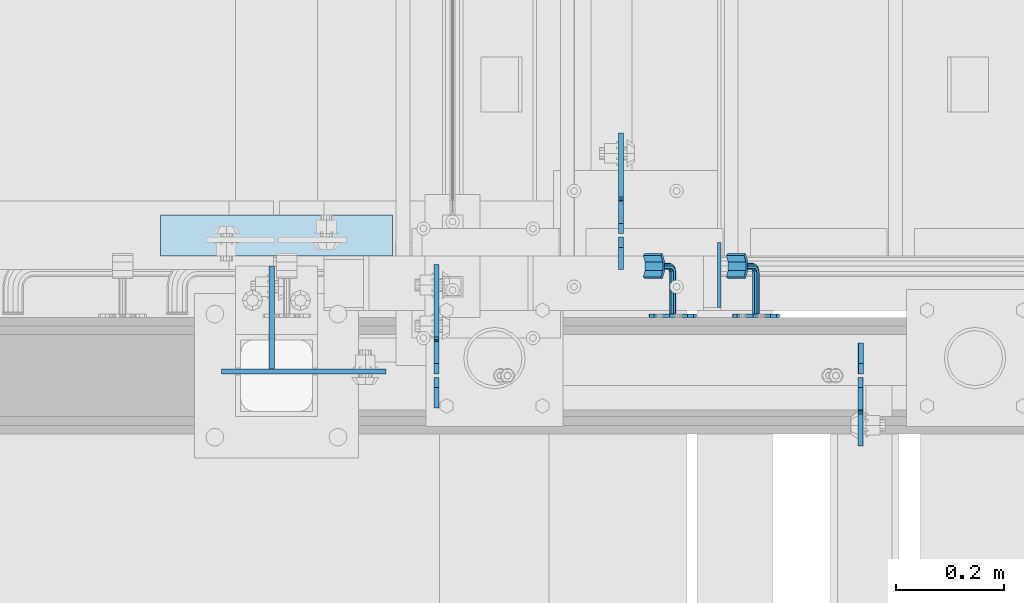
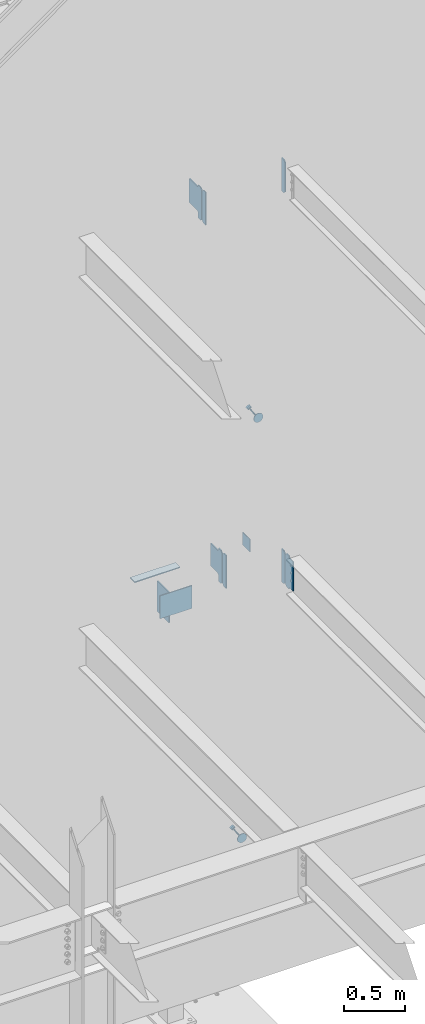
# One storey, part 1093 of 1179: 13 plates, 7 elements without a shape of their own.
"""IFC2X3 building model written with IfcOpenShell, lengths in millimetres."""

from ifc_helpers import new_model, si_unit, frame, origin_with_axes, place, context, subcontext, project, spatial, faceted_brep, material, type_object, element, aggregate, save


model = new_model("IFC2X3")

# Units and contexts
model_context = context("Model", 3, precision=1e-05, world=origin_with_axes())
body_context = subcontext(model_context, "Body", "Model", "MODEL_VIEW")
ifc_project = project(units=[si_unit("LENGTHUNIT", "METRE", prefix="MILLI"), si_unit("AREAUNIT", "SQUARE_METRE"), si_unit("VOLUMEUNIT", "CUBIC_METRE"), si_unit("MASSUNIT", "GRAM", prefix="KILO"), si_unit("TIMEUNIT", "SECOND"), si_unit("PLANEANGLEUNIT", "RADIAN"), si_unit("SOLIDANGLEUNIT", "STERADIAN"), si_unit("THERMODYNAMICTEMPERATUREUNIT", "DEGREE_CELSIUS"), si_unit("LUMINOUSINTENSITYUNIT", "LUMEN")], contexts=[model_context])

# Site, building, storey
site_placement = place(None, origin_with_axes())
site = spatial("IfcSite", under=ifc_project, at=site_placement, CompositionType="ELEMENT")
building_placement = place(site_placement, origin_with_axes())
building = spatial("IfcBuilding", under=site, at=building_placement, Name="Undefined", CompositionType="ELEMENT")
storey_placement = place(building_placement, origin_with_axes())
storey = spatial("IfcBuildingStorey", under=building, at=storey_placement, Name="Undefined", CompositionType="ELEMENT", Elevation=0.0)

# Assembly, plate
assembly_1_placement = place(storey_placement, origin_with_axes())
assembly_1 = element("IfcElementAssembly", 1, at=assembly_1_placement, inside=storey, Name="BEAM", AssemblyPlace="NOTDEFINED", PredefinedType="RIGID_FRAME")
ifc_material_1 = material(Name="STEEL/A36")
plate_type_1 = type_object("IfcPlateType", PredefinedType="NOTDEFINED")
plate_1_placement = place(assembly_1_placement, frame((20362.8620000839, 37982.525, 3762.375), z_axis=(0.0, 0.0, 1.0), x_axis=(0.0, -1.0, 0.0)))
plate_1 = element("IfcPlate", 2, at=plate_1_placement, type_object=plate_type_1, material=ifc_material_1, Name="PLATE", context=body_context, shape_type="Brep", body=[
    faceted_brep([(60.3249999999971, -4.76250000000073, 0.0), (60.3249999999971, 4.76250000000073, 0.0), (60.3250000523913, 4.76250000000073, 3.17500033034594), (60.3250000523913, -4.76250000000073, 3.17500033034594), (61.2917300150875, 4.76250000000073, 8.03507980551149), (61.2917300150875, -4.76250000000073, 8.03507980551149), (64.0447439248892, 4.76250000000073, 12.1552562262682), (64.0447439248892, -4.76250000000073, 12.1552562262682), (68.1649203759516, 4.76250000000073, 14.9082700907147), (68.1649203759516, -4.76250000000073, 14.9082700907147), (73.0249998617583, 4.76250000000073, 15.8749999999122), (73.0249998617583, -4.76250000000073, 15.8749999999122), (127.000004117435, -4.76250000000073, 15.8749999995416), (127.000004116067, 4.76250000000073, 15.8749999995416), (19.0499992370605, -4.76250000000073, 0.0), (0.0, -4.76250000000073, 19.0499992370605), (0.0, 4.76250000000073, 19.0499992370605), (19.0499992370605, 4.76250000000073, 0.0), (0.0, -4.76250000000073, 311.150012969971), (0.0, 4.76250000000073, 311.150012969971), (19.0499992370605, -4.76250000000073, 330.200012207031), (19.0499992370605, 4.76250000000073, 330.200012207031), (60.3250000095268, -4.76250000000073, 330.200000000001), (60.3250000095268, 4.76250000000073, 330.200000000001), (60.3250000714397, -4.76250000000073, 323.849999691947), (60.3250000714397, 4.76250000000073, 323.849999691947), (61.2917300265472, -4.76250000000073, 318.9899202097), (61.2917300265472, 4.76250000000073, 318.9899202097), (64.0447439338604, -4.76250000000073, 314.869743780706), (64.0447439338604, 4.76250000000073, 314.869743780706), (68.1649203869747, -4.76250000000073, 312.116729909506), (68.1649203869747, 4.76250000000073, 312.116729909506), (73.0249998776999, -4.76250000000073, 311.149999996991), (73.0249998776999, 4.76250000000073, 311.149999996991), (127.000004111091, -4.76250000000073, 311.149999984205), (127.000004116067, 4.76250000000073, 311.149999984205)], [[[0, 1, 2, 3]], [[3, 2, 4, 5]], [[5, 4, 6, 7]], [[7, 6, 8, 9]], [[9, 8, 10, 11]], [[12, 11, 10, 13]], [[14, 15, 16, 17]], [[15, 18, 19, 16]], [[18, 20, 21, 19]], [[21, 20, 22, 23]], [[22, 24, 25, 23]], [[26, 27, 25, 24]], [[28, 29, 27, 26]], [[30, 31, 29, 28]], [[32, 33, 31, 30]], [[34, 35, 33, 32]], [[35, 34, 12, 13]], [[8, 6, 4, 2, 1, 17, 16, 19, 21, 23, 25, 27, 29, 31, 33, 35, 13, 10]], [[0, 14, 17, 1]], [[34, 32, 30, 28, 26, 24, 22, 20, 18, 15, 14, 0, 3, 5, 7, 9, 11, 12]]]),
])

assembly_2_placement = place(storey_placement, origin_with_axes())
assembly_2 = element("IfcElementAssembly", 3, at=assembly_2_placement, inside=storey, Name="BEAM", AssemblyPlace="NOTDEFINED", PredefinedType="RIGID_FRAME")
plate_type_2 = type_object("IfcPlateType", PredefinedType="NOTDEFINED")
plate_2_placement = place(assembly_2_placement, frame((19575.4625, 37982.525, 7673.975), z_axis=(0.0, 0.0, 1.0), x_axis=(0.0, -1.0, 0.0)))
plate_2 = element("IfcPlate", 4, at=plate_2_placement, type_object=plate_type_2, material=ifc_material_1, Name="PLATE", context=body_context, shape_type="Brep", body=[
    faceted_brep([(0.0, -4.76250000000073, 19.0499992370605), (0.0, -4.76250000000073, 311.150012969971), (0.0, 4.76250000000073, 311.150012969971), (0.0, 4.76250000000073, 19.0499992370605), (19.0499992370605, -4.76250000000073, 330.200012207031), (19.0499992370605, 4.76250000000073, 330.200012207031), (57.1500015258789, -4.76250000000073, 330.200012207031), (57.1500015258789, 4.76250000000073, 330.200012207031), (57.1500015258789, -4.76250000000073, 0.0), (57.1500015258789, 4.76250000000073, 0.0), (19.0499992370605, -4.76250000000073, 0.0), (19.0499992370605, 4.76250000000073, 0.0)], [[[0, 1, 2, 3]], [[1, 4, 5, 2]], [[4, 6, 7, 5]], [[6, 8, 9, 7]], [[8, 10, 11, 9]], [[10, 0, 3, 11]], [[5, 7, 9, 11, 3, 2]], [[10, 8, 6, 4, 1, 0]]]),
])

# Plate
plate_3_placement = place(assembly_1_placement, frame((20362.8625, 37988.875, 3762.375), z_axis=(0.0, 0.0, 1.0), x_axis=(0.0, 1.0, 0.0)))
plate_3 = element("IfcPlate", 5, at=plate_3_placement, type_object=plate_type_2, material=ifc_material_1, Name="PLATE", context=body_context, shape_type="Brep", body=[
    faceted_brep([(0.0, -4.76250000000073, 19.0499992370605), (0.0, -4.76250000000073, 311.150012969971), (0.0, 4.76250000000073, 311.150012969971), (0.0, 4.76250000000073, 19.0499992370605), (19.0499992370605, -4.76250000000073, 330.200012207031), (19.0499992370605, 4.76250000000073, 330.200012207031), (57.1500015258789, -4.76250000000073, 330.200012207031), (57.1500015258789, 4.76250000000073, 330.200012207031), (57.1500015258789, -4.76250000000073, 0.0), (57.1500015258789, 4.76250000000073, 0.0), (19.0499992370605, -4.76250000000073, 0.0), (19.0499992370605, 4.76250000000073, 0.0)], [[[0, 1, 2, 3]], [[1, 4, 5, 2]], [[4, 6, 7, 5]], [[6, 8, 9, 7]], [[8, 10, 11, 9]], [[10, 0, 3, 11]], [[5, 7, 9, 11, 3, 2]], [[10, 8, 6, 4, 1, 0]]]),
])

aggregate(assembly_1, [plate_3, plate_1])

plate_4_placement = place(assembly_2_placement, frame((20363.6556310585, 37988.875, 7673.975), z_axis=(0.0, 0.0, 1.0), x_axis=(0.0, 1.0, 0.0)))
plate_4 = element("IfcPlate", 6, at=plate_4_placement, type_object=plate_type_2, material=ifc_material_1, Name="PLATE", context=body_context, shape_type="Brep", body=[
    faceted_brep([(0.0, -4.76250000000073, 19.0499992370605), (0.0, -4.76250000000073, 311.150012969971), (0.0, 4.76250000000073, 311.150012969971), (0.0, 4.76250000000073, 19.0499992370605), (19.0499992370605, -4.76250000000073, 330.200012207031), (19.0499992370605, 4.76250000000073, 330.200012207031), (57.1500015258789, -4.76250000000073, 330.200012207031), (57.1500015258789, 4.76250000000073, 330.200012207031), (57.1500015258789, -4.76250000000073, 0.0), (57.1500015258789, 4.76250000000073, 0.0), (19.0499992370605, -4.76250000000073, 0.0), (19.0499992370605, 4.76250000000073, 0.0)], [[[0, 1, 2, 3]], [[1, 4, 5, 2]], [[4, 6, 7, 5]], [[6, 8, 9, 7]], [[8, 10, 11, 9]], [[10, 0, 3, 11]], [[5, 7, 9, 11, 3, 2]], [[10, 8, 6, 4, 1, 0]]]),
])

# Assembly, plate
assembly_3_placement = place(storey_placement, origin_with_axes())
assembly_3 = element("IfcElementAssembly", 7, at=assembly_3_placement, inside=storey, Name="HANDRAIL", AssemblyPlace="NOTDEFINED", PredefinedType="RIGID_FRAME")
ifc_material_2 = material(Name="STEEL/BUY-OUT")
plate_type_3 = type_object("IfcPlateType", PredefinedType="NOTDEFINED")
plate_5_placement = place(assembly_3_placement, frame((20229.7217042504, 38096.8249999748, 5420.57110500949), z_axis=(-0.503209296841367, 0.0, 0.864164569727559), x_axis=(-0.864164569727559, 0.0, -0.503209296841368)))
plate_5 = element("IfcPlate", 8, at=plate_5_placement, type_object=plate_type_3, material=ifc_material_2, Name="BRACKET", context=body_context, shape_type="Brep", body=[
    faceted_brep([(3.38355483805572, -3.17500000000291, 61.4602780976829), (13.0191037998557, -3.17500000000291, 75.8808962003231), (13.0191037998557, 3.17500000000291, 75.8808962003231), (3.38355483805572, 3.17500000000291, 61.4602780976829), (27.439721902505, -3.17500000000291, 85.5164451621013), (27.439721902505, 3.17500000000291, 85.5164451621013), (44.449999237233, -3.17500000000291, 88.900000000056), (44.449999237233, 3.17500000000291, 88.900000000056), (61.4602780978275, -3.17500000000291, 85.5164451621104), (61.4602780978275, 3.17500000000291, 85.5164451621104), (75.8808962004478, -3.17500000000291, 75.8808962003413), (75.8808962004478, 3.17500000000291, 75.8808962003413), (85.5164451621931, -3.17500000000291, 61.4602780977075), (85.5164451621931, 3.17500000000291, 61.4602780977075), (88.9000000001142, -3.17500000000291, 44.4500007629867), (88.9000000001142, 3.17500000000291, 44.4500007629867), (85.5164451621349, -3.17500000000291, 27.4397219023849), (85.5164451621349, 3.17500000000291, 27.4397219023849), (75.880896200335, -3.17500000000291, 13.0191037997447), (75.880896200335, 3.17500000000291, 13.0191037997447), (61.460278097682, -3.17500000000291, 3.38355483796659), (61.460278097682, 3.17500000000291, 3.38355483796659), (44.450000762954, -3.17500000000291, 1.18234311230481e-11), (44.450000762954, 3.17500000000291, 1.18234311230481e-11), (27.4397219023631, -3.17500000000291, 3.38355483795749), (27.4397219023631, 3.17500000000291, 3.38355483795749), (13.0191037997429, -3.17500000000291, 13.0191037997274), (13.0191037997429, 3.17500000000291, 13.0191037997274), (3.38355483799751, -3.17500000000291, 27.4397219023613), (3.38355483799751, 3.17500000000291, 27.4397219023613), (7.6397554948926e-11, -3.17500000000291, 44.4500007629631), (7.6397554948926e-11, 3.17500000000291, 44.4500007629631), (50.7999999913809, -79.375000189706, 44.450000918423), (48.9401280518978, -79.375000189706, 39.9598728578721), (48.9401280518978, -3.17500000000291, 39.9598728578721), (50.7999999913809, -3.17500000000291, 44.450000918423), (44.4499999913533, -79.375000189706, 38.1000009183936), (44.4499999913533, -3.17500000000291, 38.1000009183936), (39.9598719308196, -79.375000189706, 39.9598728578549), (39.9598719308196, -3.17500000000291, 39.9598728578549), (38.0999999913656, -79.375000189706, 44.4500009184003), (38.0999999913656, -3.17500000000291, 44.4500009184003), (39.9598719308487, -79.375000189706, 48.940128978953), (39.9598719308487, -3.17500000000291, 48.940128978953), (44.4499999903783, -79.375000189706, 50.8000009184298), (48.9401280519305, -79.375000189706, 48.9401289789685), (48.9401280519305, -3.17500000000291, 48.9401289789685), (44.4499999913933, -3.17500000000291, 50.8000009184325), (48.940128050941, -83.4799360644611, 50.0400432323731), (50.7999999909662, -85.7250000949134, 46.1514782660752), (48.9401280520542, -87.9700641252057, 42.2629132991351), (44.4499999917462, -88.9000000947854, 40.6522169510108), (39.9598719309761, -87.9700641248055, 42.2629132975717), (38.0999999909509, -85.7250000943604, 46.1514782638696), (39.9598719298592, -83.4799360640682, 50.0400432308115), (44.4499999901709, -82.5500000944885, 51.6507395789349), (44.4499999895997, -84.8742613387294, 53.9750008233668), (48.9401280502061, -86.4849576864799, 53.0450648546439), (39.9598719291243, -86.4849576858032, 53.0450648527949), (38.0999999898122, -90.3735226524441, 50.8000008223462), (39.9598719294336, -94.262087619376, 48.554936792666), (44.4499999900399, -95.8727839671337, 47.6250008239376), (48.9401280505153, -94.2620876200599, 48.5549367945105), (50.7999999898311, -90.3735226534118, 50.8000008249601), (48.940128049202, -87.5848719388305, 57.150000729499), (50.7999999882741, -92.0749999995314, 57.1500007303257), (44.4499999882682, -85.7249999989726, 57.1500007282275), (39.9598719281203, -87.5848719380447, 57.1500007272562), (38.0999999882624, -92.0749999984182, 57.1500007271543), (39.9598719273345, -96.5651280591119, 57.150000727981), (44.4499999877116, -98.4249999989697, 57.1500007292507), (48.9401280484162, -96.5651280598977, 57.150000730222), (48.94012803636, -96.5651280554303, 107.980205186974), (50.7999999758504, -92.0749999949039, 107.980205187367), (44.4499999758082, -98.4249999948734, 107.980205185997), (39.9598719152818, -96.5651280553866, 107.980205185009), (38.0999999758387, -92.0749999948384, 107.980205184591), (39.9598719153255, -87.5848719343194, 107.980205184981), (44.4499999758445, -85.7249999948763, 107.980205185959), (48.9401280364073, -87.584871934363, 107.980205186946), (63.4999999710089, -112.173153287971, 121.386761918008), (25.3999999709486, -112.173153273812, 121.386761909694), (25.3999999709413, -115.348153273233, 115.887500595331), (63.499999970998, -115.348153287392, 115.887500603646), (63.4999999770953, -99.950838506069, 114.330205190187), (25.3999999770385, -99.9508384918445, 114.330205181834), (63.4999999830179, -84.3037932516017, 114.330205190117), (25.3999999829539, -84.3037932373336, 114.330205181805), (63.4999999860993, -72.081478471373, 121.386761924126), (25.3999999860353, -72.0814784571267, 121.386761915784), (25.3999999849657, -82.6023158642492, 107.980205181794), (25.3999999777625, -101.652315863423, 107.98020518183), (25.3999999884181, -68.9064784552756, 115.887500602809), (63.4999999778265, -101.652315877654, 107.980205190185), (63.4999999850261, -82.6023158785247, 107.980205190103), (63.4999999884785, -68.906478469522, 115.887500611152)], [[[0, 1, 2, 3]], [[1, 4, 5, 2]], [[4, 6, 7, 5]], [[6, 8, 9, 7]], [[8, 10, 11, 9]], [[10, 12, 13, 11]], [[12, 14, 15, 13]], [[14, 16, 17, 15]], [[16, 18, 19, 17]], [[18, 20, 21, 19]], [[20, 22, 23, 21]], [[22, 24, 25, 23]], [[24, 26, 27, 25]], [[26, 28, 29, 27]], [[28, 30, 31, 29]], [[2, 5, 7, 9, 11, 13, 15, 17, 19, 21, 23, 25, 27, 29, 31, 3]], [[30, 0, 3, 31]], [[32, 33, 34, 35]], [[33, 36, 37, 34]], [[36, 38, 39, 37]], [[38, 40, 41, 39]], [[40, 42, 43, 41]], [[44, 45, 46, 47]], [[42, 44, 47, 43]], [[28, 26, 24, 22, 20, 18, 16, 14, 12, 10, 8, 6, 4, 1, 0, 30], [46, 35, 34, 37, 39, 41, 43, 47]], [[45, 32, 35, 46]], [[32, 45, 48, 49]], [[33, 32, 49, 50]], [[36, 33, 50, 51]], [[38, 36, 51, 52]], [[40, 38, 52, 53]], [[42, 40, 53, 54]], [[44, 42, 54, 55]], [[45, 44, 55, 48]], [[55, 56, 57, 48]], [[54, 58, 56, 55]], [[53, 59, 58, 54]], [[52, 60, 59, 53]], [[51, 61, 60, 52]], [[50, 62, 61, 51]], [[49, 63, 62, 50]], [[48, 57, 63, 49]], [[57, 64, 65, 63]], [[56, 66, 64, 57]], [[58, 67, 66, 56]], [[59, 68, 67, 58]], [[60, 69, 68, 59]], [[61, 70, 69, 60]], [[62, 71, 70, 61]], [[63, 65, 71, 62]], [[72, 71, 65, 73]], [[74, 70, 71, 72]], [[75, 69, 70, 74]], [[76, 68, 69, 75]], [[77, 67, 68, 76]], [[78, 66, 67, 77]], [[79, 64, 66, 78]], [[73, 65, 64, 79]], [[80, 81, 82, 83]], [[81, 80, 84, 85]], [[85, 84, 86, 87]], [[87, 86, 88, 89]], [[90, 91, 82, 81, 85, 87, 89, 92]], [[83, 82, 91, 93]], [[86, 84, 80, 83, 93, 94, 95, 88]], [[89, 88, 95, 92]], [[94, 90, 92, 95]], [[93, 91, 90, 94], [78, 77, 76, 75, 74, 72, 73, 79]]]),
])
aggregate(assembly_3, [plate_5])

assembly_4_placement = place(storey_placement, origin_with_axes())
assembly_4 = element("IfcElementAssembly", 9, at=assembly_4_placement, inside=storey, Name="HANDRAIL", AssemblyPlace="NOTDEFINED", PredefinedType="RIGID_FRAME")
plate_6_placement = place(assembly_4_placement, frame((20075.1918322975, 38096.8249999748, 1269.24367168925), z_axis=(-0.500231016985973, 0.0, 0.865891984975712), x_axis=(-0.865891984975713, 0.0, -0.500231016985972)))
plate_6 = element("IfcPlate", 10, at=plate_6_placement, type_object=plate_type_3, material=ifc_material_2, Name="BRACKET", context=body_context, shape_type="Brep", body=[
    faceted_brep([(3.38355483805572, -3.17500000000291, 61.4602780976829), (13.0191037998557, -3.17500000000291, 75.8808962003231), (13.0191037998557, 3.17500000000291, 75.8808962003231), (3.38355483805572, 3.17500000000291, 61.4602780976829), (27.439721902505, -3.17500000000291, 85.5164451621013), (27.439721902505, 3.17500000000291, 85.5164451621013), (44.449999237233, -3.17500000000291, 88.900000000056), (44.449999237233, 3.17500000000291, 88.900000000056), (61.4602780978275, -3.17500000000291, 85.5164451621104), (61.4602780978275, 3.17500000000291, 85.5164451621104), (75.8808962004478, -3.17500000000291, 75.8808962003413), (75.8808962004478, 3.17500000000291, 75.8808962003413), (85.5164451621931, -3.17500000000291, 61.4602780977075), (85.5164451621931, 3.17500000000291, 61.4602780977075), (88.9000000001142, -3.17500000000291, 44.4500007629867), (88.9000000001142, 3.17500000000291, 44.4500007629867), (85.5164451621349, -3.17500000000291, 27.4397219023849), (85.5164451621349, 3.17500000000291, 27.4397219023849), (75.880896200335, -3.17500000000291, 13.0191037997447), (75.880896200335, 3.17500000000291, 13.0191037997447), (61.460278097682, -3.17500000000291, 3.38355483796659), (61.460278097682, 3.17500000000291, 3.38355483796659), (44.450000762954, -3.17500000000291, 1.18234311230481e-11), (44.450000762954, 3.17500000000291, 1.18234311230481e-11), (27.4397219023631, -3.17500000000291, 3.38355483795749), (27.4397219023631, 3.17500000000291, 3.38355483795749), (13.0191037997429, -3.17500000000291, 13.0191037997274), (13.0191037997429, 3.17500000000291, 13.0191037997274), (3.38355483799751, -3.17500000000291, 27.4397219023613), (3.38355483799751, 3.17500000000291, 27.4397219023613), (7.6397554948926e-11, -3.17500000000291, 44.4500007629631), (7.6397554948926e-11, 3.17500000000291, 44.4500007629631), (50.7999999913809, -79.375000189706, 44.450000918423), (48.9401280518978, -79.375000189706, 39.9598728578721), (48.9401280518978, -3.17500000000291, 39.9598728578721), (50.7999999913809, -3.17500000000291, 44.450000918423), (44.4499999913533, -79.375000189706, 38.1000009183936), (44.4499999913533, -3.17500000000291, 38.1000009183936), (39.9598719308196, -79.375000189706, 39.9598728578549), (39.9598719308196, -3.17500000000291, 39.9598728578549), (38.0999999913656, -79.375000189706, 44.4500009184003), (38.0999999913656, -3.17500000000291, 44.4500009184003), (39.9598719308487, -79.375000189706, 48.940128978953), (39.9598719308487, -3.17500000000291, 48.940128978953), (44.4499999903783, -79.375000189706, 50.8000009184298), (48.9401280519305, -79.375000189706, 48.9401289789685), (48.9401280519305, -3.17500000000291, 48.9401289789685), (44.4499999913933, -3.17500000000291, 50.8000009184325), (48.940128050941, -83.4799360644611, 50.0400432323731), (50.7999999909662, -85.7250000949134, 46.1514782660752), (48.9401280520542, -87.9700641252057, 42.2629132991351), (44.4499999917462, -88.9000000947854, 40.6522169510108), (39.9598719309761, -87.9700641248055, 42.2629132975717), (38.0999999909509, -85.7250000943604, 46.1514782638696), (39.9598719298592, -83.4799360640682, 50.0400432308115), (44.4499999901709, -82.5500000944885, 51.6507395789349), (44.4499999895997, -84.8742613387294, 53.9750008233668), (48.9401280502061, -86.4849576864799, 53.0450648546439), (39.9598719291243, -86.4849576858032, 53.0450648527949), (38.0999999898122, -90.3735226524441, 50.8000008223462), (39.9598719294336, -94.262087619376, 48.554936792666), (44.4499999900399, -95.8727839671337, 47.6250008239376), (48.9401280505153, -94.2620876200599, 48.5549367945105), (50.7999999898311, -90.3735226534118, 50.8000008249601), (48.940128049202, -87.5848719388305, 57.150000729499), (50.7999999882741, -92.0749999995314, 57.1500007303257), (44.4499999882682, -85.7249999989726, 57.1500007282275), (39.9598719281203, -87.5848719380447, 57.1500007272562), (38.0999999882624, -92.0749999984182, 57.1500007271543), (39.9598719273345, -96.5651280591119, 57.150000727981), (44.4499999877116, -98.4249999989697, 57.1500007292507), (48.9401280484162, -96.5651280598977, 57.150000730222), (48.94012803636, -96.5651280554303, 107.980205186974), (50.7999999758504, -92.0749999949039, 107.980205187367), (44.4499999758082, -98.4249999948734, 107.980205185997), (39.9598719152818, -96.5651280553866, 107.980205185009), (38.0999999758387, -92.0749999948384, 107.980205184591), (39.9598719153255, -87.5848719343194, 107.980205184981), (44.4499999758445, -85.7249999948763, 107.980205185959), (48.9401280364073, -87.584871934363, 107.980205186946), (63.4999999710089, -112.173153287971, 121.386761918008), (25.3999999709486, -112.173153273812, 121.386761909694), (25.3999999709413, -115.348153273233, 115.887500595331), (63.499999970998, -115.348153287392, 115.887500603646), (63.4999999770953, -99.950838506069, 114.330205190187), (25.3999999770385, -99.9508384918445, 114.330205181834), (63.4999999830179, -84.3037932516017, 114.330205190117), (25.3999999829539, -84.3037932373336, 114.330205181805), (63.4999999860993, -72.081478471373, 121.386761924126), (25.3999999860353, -72.0814784571267, 121.386761915784), (25.3999999849657, -82.6023158642492, 107.980205181794), (25.3999999777625, -101.652315863423, 107.98020518183), (25.3999999884181, -68.9064784552756, 115.887500602809), (63.4999999778265, -101.652315877654, 107.980205190185), (63.4999999850261, -82.6023158785247, 107.980205190103), (63.4999999884785, -68.906478469522, 115.887500611152)], [[[0, 1, 2, 3]], [[1, 4, 5, 2]], [[4, 6, 7, 5]], [[6, 8, 9, 7]], [[8, 10, 11, 9]], [[10, 12, 13, 11]], [[12, 14, 15, 13]], [[14, 16, 17, 15]], [[16, 18, 19, 17]], [[18, 20, 21, 19]], [[20, 22, 23, 21]], [[22, 24, 25, 23]], [[24, 26, 27, 25]], [[26, 28, 29, 27]], [[28, 30, 31, 29]], [[2, 5, 7, 9, 11, 13, 15, 17, 19, 21, 23, 25, 27, 29, 31, 3]], [[30, 0, 3, 31]], [[32, 33, 34, 35]], [[33, 36, 37, 34]], [[36, 38, 39, 37]], [[38, 40, 41, 39]], [[40, 42, 43, 41]], [[44, 45, 46, 47]], [[42, 44, 47, 43]], [[28, 26, 24, 22, 20, 18, 16, 14, 12, 10, 8, 6, 4, 1, 0, 30], [46, 35, 34, 37, 39, 41, 43, 47]], [[45, 32, 35, 46]], [[32, 45, 48, 49]], [[33, 32, 49, 50]], [[36, 33, 50, 51]], [[38, 36, 51, 52]], [[40, 38, 52, 53]], [[42, 40, 53, 54]], [[44, 42, 54, 55]], [[45, 44, 55, 48]], [[55, 56, 57, 48]], [[54, 58, 56, 55]], [[53, 59, 58, 54]], [[52, 60, 59, 53]], [[51, 61, 60, 52]], [[50, 62, 61, 51]], [[49, 63, 62, 50]], [[48, 57, 63, 49]], [[57, 64, 65, 63]], [[56, 66, 64, 57]], [[58, 67, 66, 56]], [[59, 68, 67, 58]], [[60, 69, 68, 59]], [[61, 70, 69, 60]], [[62, 71, 70, 61]], [[63, 65, 71, 62]], [[72, 71, 65, 73]], [[74, 70, 71, 72]], [[75, 69, 70, 74]], [[76, 68, 69, 75]], [[77, 67, 68, 76]], [[78, 66, 67, 77]], [[79, 64, 66, 78]], [[73, 65, 64, 79]], [[80, 81, 82, 83]], [[81, 80, 84, 85]], [[85, 84, 86, 87]], [[87, 86, 88, 89]], [[90, 91, 82, 81, 85, 87, 89, 92]], [[83, 82, 91, 93]], [[86, 84, 80, 83, 93, 94, 95, 88]], [[89, 88, 95, 92]], [[94, 90, 92, 95]], [[93, 91, 90, 94], [78, 77, 76, 75, 74, 72, 73, 79]]]),
])
aggregate(assembly_4, [plate_6])

assembly_5_placement = place(storey_placement, origin_with_axes())
assembly_5 = element("IfcElementAssembly", 11, at=assembly_5_placement, inside=storey, Name="COLUMN", AssemblyPlace="NOTDEFINED", PredefinedType="RIGID_FRAME")
plate_type_4 = type_object("IfcPlateType", PredefinedType="NOTDEFINED")
plate_7_placement = place(assembly_5_placement, frame((19367.5, 37993.6375, 4064.0), z_axis=(0.0, 0.0, -1.0), x_axis=(-1.0, 0.0, 0.0)))
plate_7 = element("IfcPlate", 12, at=plate_7_placement, type_object=plate_type_4, material=ifc_material_1, Name="PLATE", context=body_context, shape_type="Brep", body=[
    faceted_brep([(0.0, -4.76249999999709, 0.0), (-114.300000000003, -4.76250000000073, 0.0), (-114.300000000003, 4.76250000000073, 0.0), (0.0, 4.76249999999709, 0.0), (-114.299999999999, -4.76249999999709, 228.599999999999), (-114.299999999999, 4.76249999999709, 228.599999999999), (190.5, -4.76249999999709, 228.599999999999), (190.5, 4.76249999999709, 228.599999999999), (190.5, -4.76249999999709, 0.0), (190.5, 4.76249999999709, 0.0)], [[[0, 1, 2, 3]], [[1, 4, 5, 2]], [[4, 6, 7, 5]], [[6, 8, 9, 7]], [[8, 0, 3, 9]], [[5, 7, 9, 3, 2]], [[8, 6, 4, 1, 0]]]),
])

assembly_6_placement = place(storey_placement, origin_with_axes())
assembly_6 = element("IfcElementAssembly", 13, at=assembly_6_placement, inside=storey, Name="PLATE", AssemblyPlace="NOTDEFINED", PredefinedType="RIGID_FRAME")
plate_type_5 = type_object("IfcPlateType", PredefinedType="NOTDEFINED")
plate_8_placement = place(assembly_6_placement, frame((19493.70625, 38284.1500000005, 4106.8625), z_axis=(0.0, -1.0, 0.0), x_axis=(-1.0, 0.0, 0.0)))
plate_8 = element("IfcPlate", 14, at=plate_8_placement, type_object=plate_type_5, material=ifc_material_1, Name="PLATE", context=body_context, shape_type="Brep", body=[
    faceted_brep([(0.0, -4.76249999999709, 0.0), (0.0, -4.76249999999982, 76.1999999999971), (0.0, 4.76249999999982, 76.1999999999971), (0.0, 4.76249999999709, 0.0), (430.212500000001, -4.76249999999982, 76.1999999999971), (430.212500000001, 4.76249999999982, 76.1999999999971), (430.212500000001, -4.76249999999982, 0.0), (430.212500000001, 4.76249999999982, 0.0)], [[[0, 1, 2, 3]], [[1, 4, 5, 2]], [[4, 6, 7, 5]], [[6, 0, 3, 7]], [[5, 7, 3, 2]], [[6, 4, 1, 0]]]),
])
aggregate(assembly_6, [plate_8])

assembly_7_placement = place(storey_placement, origin_with_axes())
assembly_7 = element("IfcElementAssembly", 15, at=assembly_7_placement, inside=storey, Name="BEAM", AssemblyPlace="NOTDEFINED", PredefinedType="RIGID_FRAME")
plate_type_6 = type_object("IfcPlateType", PredefinedType="NOTDEFINED")
plate_9_placement = place(assembly_7_placement, frame((19918.3620000839, 38249.2250000005, 3781.425), z_axis=(0.0, 0.707106781186542, 0.707106781186553), x_axis=(0.0, 0.707106781186553, -0.707106781186542)))
plate_9 = element("IfcPlate", 16, at=plate_9_placement, type_object=plate_type_6, material=ifc_material_1, Name="PLATE", context=body_context, shape_type="Brep", body=[
    faceted_brep([(0.0, -4.76249999999709, 0.0), (-206.545890784662, -4.76250000000073, 206.545890784655), (-206.545890784662, 4.76250000000073, 206.545890784655), (0.0, 4.76249999999709, 0.0), (-206.545890784728, -4.76250000000073, 233.486659147802), (-206.545890784728, 4.76250000000073, 233.486659147802), (-177.360058391398, -4.76250000000073, 262.672491541136), (-177.360058391398, 4.76250000000073, 262.672491541136), (-166.134738105186, -4.76250000000073, 251.447171254924), (-166.134738105186, 4.76250000000073, 251.447171254924), (-162.014561637032, -4.76250000000073, 248.694157354446), (-162.014561637032, 4.76250000000073, 248.694157354446), (-157.154482118993, -4.76250000000073, 247.727427431852), (-157.154482118993, 4.76250000000073, 247.727427431852), (-152.294402600954, -4.76250000000073, 248.694157354432), (-152.294402600954, 4.76250000000073, 248.694157354432), (-148.174226132807, -4.76250000000073, 251.447171254902), (-148.174226132807, 4.76250000000073, 251.447171254902), (-67.3519209087317, -4.76250000000073, 332.269476478985), (-67.3519209087317, 4.76250000000073, 332.269476478985), (94.2926892705727, -4.76250000000073, 170.624866299691), (94.2926892705727, 4.76250000000073, 170.624866299691), (13.4703840464972, -4.76250000000073, 89.8025610756085), (13.4703840464972, 4.76250000000073, 89.8025610756085), (10.717370146027, -4.76250000000073, 85.6823846074622), (10.717370146027, 4.76250000000073, 85.6823846074622), (9.75064022344668, -4.76250000000073, 80.822305089423), (9.75064022344668, 4.76250000000073, 80.822305089423), (10.7173701460415, -4.76250000000073, 75.9622255713839), (10.7173701460415, 4.76250000000073, 75.9622255713839), (13.470384046519, -4.76250000000073, 71.8420491032302), (13.470384046519, 4.76250000000073, 71.8420491032302), (56.1266007564882, -4.76250000000073, 29.1858323932647), (56.1266007564882, 4.76250000000073, 29.1858323932647), (26.9407683631525, -4.76249999999709, -6.18456397205591e-11), (26.9407683631525, 4.76249999999709, -6.18456397205591e-11)], [[[0, 1, 2, 3]], [[1, 4, 5, 2]], [[4, 6, 7, 5]], [[6, 8, 9, 7]], [[8, 10, 11, 9]], [[10, 12, 13, 11]], [[12, 14, 15, 13]], [[14, 16, 17, 15]], [[16, 18, 19, 17]], [[18, 20, 21, 19]], [[20, 22, 23, 21]], [[22, 24, 25, 23]], [[24, 26, 27, 25]], [[26, 28, 29, 27]], [[28, 30, 31, 29]], [[30, 32, 33, 31]], [[32, 34, 35, 33]], [[34, 0, 3, 35]], [[5, 7, 9, 11, 13, 15, 17, 19, 21, 23, 25, 27, 29, 31, 33, 35, 3, 2]], [[34, 32, 30, 28, 26, 24, 22, 20, 18, 16, 14, 12, 10, 8, 6, 4, 1, 0]]]),
])

# Plate
plate_type_7 = type_object("IfcPlateType", PredefinedType="NOTDEFINED")
plate_10_placement = place(assembly_5_placement, frame((19269.86875, 38074.6, 4064.0), z_axis=(0.0, 0.0, -1.0), x_axis=(0.0, -1.0, 0.0)))
plate_10 = element("IfcPlate", 17, at=plate_10_placement, type_object=plate_type_7, material=ifc_material_1, Name="PLATE", context=body_context, shape_type="Brep", body=[
    faceted_brep([(0.0, -4.76249999999709, 0.0), (-114.300000000003, -4.76250000000073, 0.0), (-114.300000000003, 4.76250000000073, 0.0), (0.0, 4.76249999999709, 0.0), (-114.300000000003, -4.76250000000073, 304.8), (-114.300000000003, 4.76250000000073, 304.8), (76.2000000000044, -4.76250000000073, 304.8), (76.2000000000044, 4.76250000000073, 304.8), (76.1999999999971, -4.76249999999999, 0.0), (76.1999999999971, 4.76249999999999, 0.0)], [[[0, 1, 2, 3]], [[1, 4, 5, 2]], [[4, 6, 7, 5]], [[6, 8, 9, 7]], [[8, 0, 3, 9]], [[5, 7, 9, 3, 2]], [[8, 6, 4, 1, 0]]]),
])

aggregate(assembly_5, [plate_10, plate_7])

plate_type_8 = type_object("IfcPlateType", PredefinedType="NOTDEFINED")
plate_11_placement = place(assembly_7_placement, frame((20100.925, 38112.7000000005, 4235.45), z_axis=(0.0, 1.0, 0.0), x_axis=(0.0, 0.0, -1.0)))
plate_11 = element("IfcPlate", 18, at=plate_11_placement, type_object=plate_type_8, material=ifc_material_1, Name="PLATE", context=body_context, shape_type="Brep", body=[
    faceted_brep([(0.0, -3.17500000000109, 0.0), (0.0, -3.17499999999927, 120.649999999994), (0.0, 3.17499999999927, 120.649999999994), (0.0, 3.17500000000109, 7.27595761418343e-12), (126.999999999999, -3.17499999999927, 120.649999999994), (126.999999999999, 3.17499999999927, 120.649999999994), (127.000000000002, -3.17500000000291, 0.0), (127.000000000002, 3.17500000000291, 0.0)], [[[0, 1, 2, 3]], [[1, 4, 5, 2]], [[4, 6, 7, 5]], [[6, 0, 3, 7]], [[5, 7, 3, 2]], [[6, 4, 1, 0]]]),
])

plate_type_9 = type_object("IfcPlateType", PredefinedType="NOTDEFINED")
plate_12_placement = place(assembly_7_placement, frame((19918.3620000839, 38242.8750000005, 3762.375), z_axis=(0.0, 0.0, 1.0), x_axis=(0.0, -1.0, 0.0)))
plate_12 = element("IfcPlate", 19, at=plate_12_placement, type_object=plate_type_9, material=ifc_material_1, Name="PLATE", context=body_context, shape_type="Brep", body=[
    faceted_brep([(0.0, -4.76250000000073, 19.0499992370605), (0.0, -4.76250000000073, 311.150012969971), (0.0, 4.76250000000073, 311.150012969971), (0.0, 4.76250000000073, 19.0499992370605), (19.0499992370605, -4.76250000000073, 330.200012207031), (19.0499992370605, 4.76250000000073, 330.200012207031), (60.3250000095268, -4.76250000000073, 330.200000000001), (60.3250000095268, 4.76250000000073, 330.200000000001), (60.3249999999971, -4.76250000000073, 0.0), (60.3249999999971, 4.76250000000073, 0.0), (19.0499992370605, -4.76250000000073, 0.0), (19.0499992370605, 4.76250000000073, 0.0)], [[[0, 1, 2, 3]], [[1, 4, 5, 2]], [[5, 4, 6, 7]], [[6, 8, 9, 7]], [[8, 10, 11, 9]], [[10, 0, 3, 11]], [[5, 7, 9, 11, 3, 2]], [[10, 8, 6, 4, 1, 0]]]),
])

aggregate(assembly_7, [plate_11, plate_12, plate_9])

plate_type_10 = type_object("IfcPlateType", PredefinedType="NOTDEFINED")
plate_13_placement = place(assembly_2_placement, frame((19575.4625, 37988.875, 7673.975), z_axis=(0.0, 0.0, 1.0), x_axis=(0.0, 1.0, 0.0)))
plate_13 = element("IfcPlate", 20, at=plate_13_placement, type_object=plate_type_10, material=ifc_material_1, Name="PLATE", context=body_context, shape_type="Brep", body=[
    faceted_brep([(60.3249999999971, -4.76250000000073, 0.0), (60.3249999999971, 4.76250000000073, 0.0), (60.3250026542883, 4.76250000000073, 53.9749990552664), (60.3250026542883, -4.76250000000073, 53.9749990552664), (61.2917325768794, 4.76250000000073, 58.8350785733119), (61.2917325768794, -4.76250000000073, 58.8350785733119), (64.0447464773533, 4.76250000000073, 62.9552550414655), (64.0447464773533, -4.76250000000073, 62.9552550414655), (68.164922945507, 4.76250000000073, 65.708268941944), (68.164922945507, -4.76250000000073, 65.708268941944), (73.0250024635534, 4.76250000000073, 66.6749988645315), (73.0250024635534, -4.76250000000073, 66.6749988645315), (203.200004873048, -4.76250000000073, 66.6749988645315), (203.200004873048, 4.76250000000073, 66.6749988645315), (19.0499992370605, -4.76250000000073, 0.0), (0.0, -4.76250000000073, 19.0499992370605), (0.0, 4.76250000000073, 19.0499992370605), (19.0499992370605, 4.76250000000073, 0.0), (0.0, -4.76250000000073, 311.150012969971), (0.0, 4.76250000000073, 311.150012969971), (19.0499992370605, -4.76250000000073, 330.200012207031), (19.0499992370605, 4.76250000000073, 330.200012207031), (60.3250000095268, -4.76250000000073, 330.200000000001), (60.3250000095268, 4.76250000000073, 330.200000000001), (60.3250000888947, -4.76250000000073, 320.674999707663), (60.3250000888947, 4.76250000000073, 320.674999707663), (61.2917300406407, -4.76250000000073, 315.814920220819), (61.2917300406407, 4.76250000000073, 315.814920220819), (64.0447439478812, -4.76250000000073, 311.694743787144), (64.0447439478812, 4.76250000000073, 311.694743787144), (68.1649204035784, -4.76250000000073, 308.941729912867), (68.1649204035784, 4.76250000000073, 308.941729912867), (73.0249998981599, -4.76250000000073, 307.974999999999), (73.0249998981599, 4.76250000000073, 307.974999999999), (203.200004873048, -4.76250000000073, 307.974999999999), (203.200004873048, 4.76250000000073, 307.974999999999)], [[[0, 1, 2, 3]], [[3, 2, 4, 5]], [[5, 4, 6, 7]], [[7, 6, 8, 9]], [[9, 8, 10, 11]], [[12, 11, 10, 13]], [[14, 15, 16, 17]], [[15, 18, 19, 16]], [[18, 20, 21, 19]], [[21, 20, 22, 23]], [[22, 24, 25, 23]], [[26, 27, 25, 24]], [[28, 29, 27, 26]], [[30, 31, 29, 28]], [[32, 33, 31, 30]], [[34, 35, 33, 32]], [[35, 34, 12, 13]], [[8, 6, 4, 2, 1, 17, 16, 19, 21, 23, 25, 27, 29, 31, 33, 35, 13, 10]], [[0, 14, 17, 1]], [[34, 32, 30, 28, 26, 24, 22, 20, 18, 15, 14, 0, 3, 5, 7, 9, 11, 12]]]),
])

aggregate(assembly_2, [plate_2, plate_13, plate_4])

save(model, "model.ifc")
